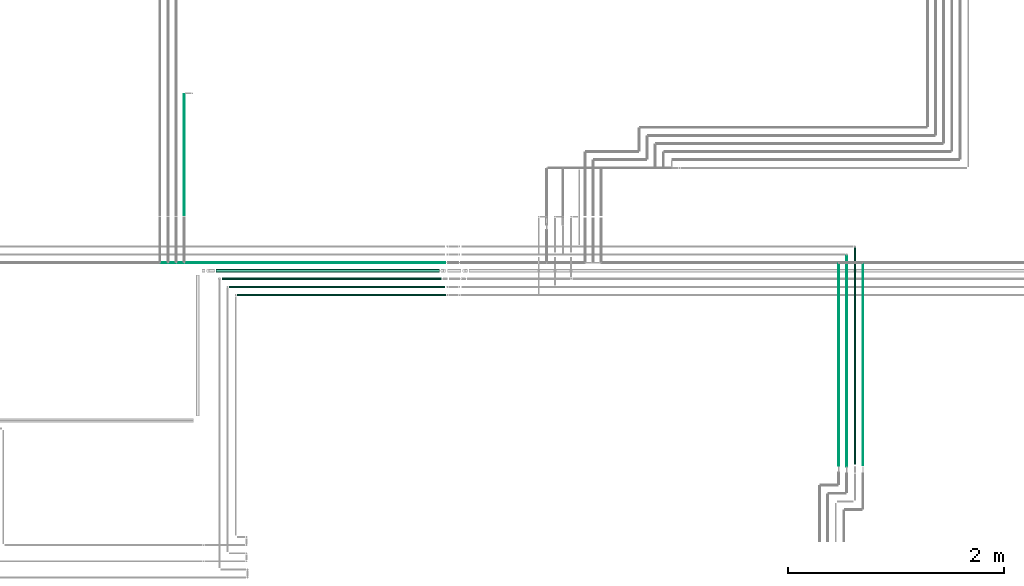
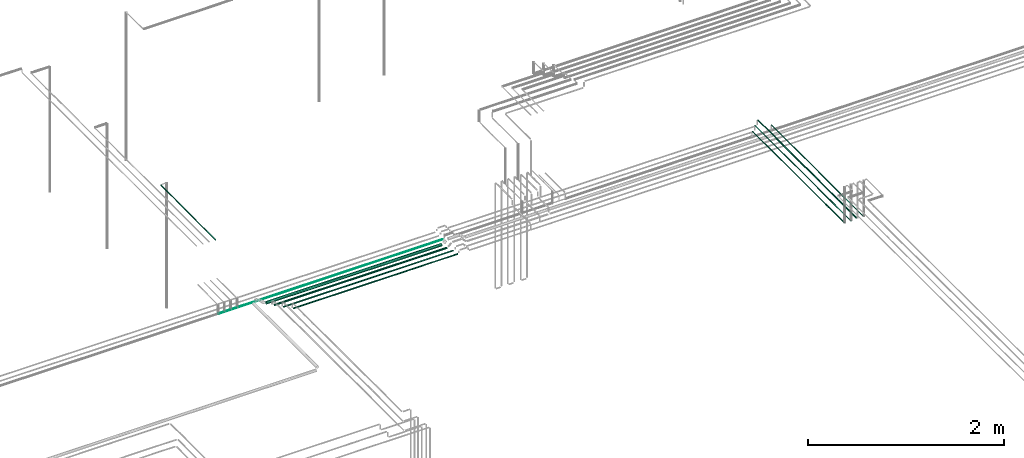
# One storey, part 25 of 331: 10 flow segments.
"""IFC2X3 building model written with IfcOpenShell, lengths in millimetres."""

from ifc_helpers import new_model, entity, si_unit, converted_unit, derived_unit, direction, frame, frame_2d, origin, origin_2d_with_axis, place, context, subcontext, project, spatial, circle, extrude, type_object, element, save


model = new_model("IFC2X3")

# Units and contexts
model_context = context("Model", 3, precision=0.01, world=origin(), true_north=direction((6.12303176911189e-17, 1.0)))
body_context = subcontext(model_context, "Body", "Model", "MODEL_VIEW")
ifc_project = project(units=[si_unit("LENGTHUNIT", "METRE", prefix="MILLI"), si_unit("AREAUNIT", "SQUARE_METRE"), si_unit("VOLUMEUNIT", "CUBIC_METRE"), converted_unit("PLANEANGLEUNIT", "DEGREE", entity("IfcRatioMeasure", 0.0174532925199433), si_unit("PLANEANGLEUNIT", "RADIAN"), dimensions=[0, 0, 0, 0, 0, 0, 0]), si_unit("MASSUNIT", "GRAM", prefix="KILO"), derived_unit("MASSDENSITYUNIT", [(si_unit("MASSUNIT", "GRAM", prefix="KILO"), 1), (si_unit("LENGTHUNIT", "METRE"), -3)]), derived_unit("MOMENTOFINERTIAUNIT", [(si_unit("LENGTHUNIT", "METRE"), 4)]), si_unit("TIMEUNIT", "SECOND"), si_unit("FREQUENCYUNIT", "HERTZ"), si_unit("THERMODYNAMICTEMPERATUREUNIT", "DEGREE_CELSIUS"), derived_unit("THERMALTRANSMITTANCEUNIT", [(si_unit("MASSUNIT", "GRAM", prefix="KILO"), 1), (si_unit("THERMODYNAMICTEMPERATUREUNIT", "KELVIN"), -1), (si_unit("TIMEUNIT", "SECOND"), -3)]), derived_unit("VOLUMETRICFLOWRATEUNIT", [(si_unit("LENGTHUNIT", "METRE"), 3), (si_unit("TIMEUNIT", "SECOND"), -1)]), derived_unit("MASSFLOWRATEUNIT", [(si_unit("MASSUNIT", "GRAM", prefix="KILO"), 1), (si_unit("TIMEUNIT", "SECOND"), -1)]), derived_unit("ROTATIONALFREQUENCYUNIT", [(si_unit("TIMEUNIT", "SECOND"), -1)]), si_unit("ELECTRICCURRENTUNIT", "AMPERE"), si_unit("ELECTRICVOLTAGEUNIT", "VOLT"), si_unit("POWERUNIT", "WATT"), si_unit("FORCEUNIT", "NEWTON", prefix="KILO"), si_unit("ILLUMINANCEUNIT", "LUX"), si_unit("LUMINOUSFLUXUNIT", "LUMEN"), si_unit("LUMINOUSINTENSITYUNIT", "CANDELA"), derived_unit("USERDEFINED", [(si_unit("MASSUNIT", "GRAM", prefix="KILO"), -1), (si_unit("LENGTHUNIT", "METRE"), -2), (si_unit("TIMEUNIT", "SECOND"), 3), (si_unit("LUMINOUSFLUXUNIT", "LUMEN"), 1)]), derived_unit("LINEARVELOCITYUNIT", [(si_unit("LENGTHUNIT", "METRE"), 1), (si_unit("TIMEUNIT", "SECOND"), -1)]), si_unit("PRESSUREUNIT", "PASCAL"), derived_unit("USERDEFINED", [(si_unit("LENGTHUNIT", "METRE"), -2), (si_unit("MASSUNIT", "GRAM", prefix="KILO"), 1), (si_unit("TIMEUNIT", "SECOND"), -2)]), derived_unit("LINEARFORCEUNIT", [(si_unit("MASSUNIT", "GRAM", prefix="KILO"), 1), (si_unit("LENGTHUNIT", "METRE"), 1), (si_unit("TIMEUNIT", "SECOND"), -2), (si_unit("LENGTHUNIT", "METRE"), -1)]), derived_unit("PLANARFORCEUNIT", [(si_unit("MASSUNIT", "GRAM", prefix="KILO"), 1), (si_unit("LENGTHUNIT", "METRE"), 1), (si_unit("TIMEUNIT", "SECOND"), -2), (si_unit("LENGTHUNIT", "METRE"), -2)])], contexts=[model_context])

# Site, building, storey
site_placement = place(None, frame((0.0, -0.00077364408347762, 0.0)))
site = spatial("IfcSite", under=ifc_project, at=site_placement, CompositionType="ELEMENT")
building_placement = place(site_placement, origin())
building = spatial("IfcBuilding", under=site, at=building_placement, CompositionType="ELEMENT")
storey_placement = place(building_placement, origin())
storey = spatial("IfcBuildingStorey", under=building, at=storey_placement, CompositionType="ELEMENT", Elevation=0.0)

# Flow segments
pipe_segment_type = type_object("IfcPipeSegmentType", PredefinedType="NOTDEFINED")
flow_segment_1_placement = place(building_placement, frame((34565.3073998838, 15805.889397967, 6655.90472776405)))
element("IfcFlowSegment", 1, at=flow_segment_1_placement, inside=storey, type_object=pipe_segment_type, context=body_context, shape_type="SweptSolid", body=[
    extrude(circle(Radius=17.5, at=frame_2d((2.16573425859679e-12, 0.0), x_axis=(1.0, 0.0))), frame((0.0, 19.0952722359184, 19.0952722359163), z_axis=(1.0, 0.0, 0.0), x_axis=(0.0, 1.0, 0.0)), (0.0, 0.0, 1.0), 2064.17813480539),
])
flow_segment_2_placement = place(building_placement, frame((40316.4101011924, 14020.0008331299, 6744.40472776409)))
element("IfcFlowSegment", 2, at=flow_segment_2_placement, inside=storey, type_object=pipe_segment_type, context=body_context, shape_type="SweptSolid", body=[
    extrude(circle(Radius=4.0, at=frame_2d((-8.66293703438714e-12, 0.0), x_axis=(1.0, 0.0))), frame((5.59527223591499, 0.0, 5.59527223591607), z_axis=(0.0, 1.0, 0.0), x_axis=(-1.0, 0.0, 0.0)), (0.0, 0.0, 1.0), 1869.98383707291),
])
flow_segment_3_placement = place(building_placement, frame((40391.4101011923, 14010.0008331299, 6744.40472776408)))
element("IfcFlowSegment", 3, at=flow_segment_3_placement, inside=storey, type_object=pipe_segment_type, context=body_context, shape_type="SweptSolid", body=[
    extrude(circle(Radius=4.0, at=frame_2d((0.0, 1.08286712929839e-12), x_axis=(1.0, 0.0))), frame((5.59527223591499, 0.0, 5.59527223591716), z_axis=(0.0, 1.0, 0.0), x_axis=(1.0, 0.0, 0.0)), (0.0, 0.0, 1.0), 1954.98383707304),
])
flow_segment_4_placement = place(building_placement, frame((40464.4101011923, 14033.0008331299, 6742.40472776409)))
element("IfcFlowSegment", 4, at=flow_segment_4_placement, inside=storey, type_object=pipe_segment_type, context=body_context, shape_type="SweptSolid", body=[
    extrude(circle(Radius=6.0, at=origin_2d_with_axis()), frame((7.59527223591454, 0.0, 7.59527223591562), z_axis=(0.0, 1.0, 0.0), x_axis=(-1.0, 0.0, 0.0)), (0.0, 0.0, 1.0), 2002.98383707304),
])
flow_segment_5_placement = place(building_placement, frame((40541.4101011924, 14027.0008331299, 6744.40472776409)))
element("IfcFlowSegment", 5, at=flow_segment_5_placement, inside=storey, type_object=pipe_segment_type, context=body_context, shape_type="SweptSolid", body=[
    extrude(circle(Radius=4.0, at=origin_2d_with_axis()), frame((5.59527223591499, 0.0, 5.59527223591607), z_axis=(0.0, 1.0, 0.0), x_axis=(-1.0, 0.0, 0.0)), (0.0, 0.0, 1.0), 1862.9838370729),
])
flow_segment_6_placement = place(storey_placement, frame((34264.8822000101, 16340.2501169888, 7244.33566793838)))
element("IfcFlowSegment", 6, at=flow_segment_6_placement, inside=storey, type_object=pipe_segment_type, context=body_context, shape_type="SweptSolid", body=[
    extrude(circle(Radius=4.0, at=origin_2d_with_axis()), frame((5.59527223591499, 0.000247807158046953, 5.59527222823855), z_axis=(0.0, 1.0, 6.19517897553015e-05), x_axis=(-1.0, 0.0, 0.0)), (0.0, 0.0, 1.0), 1114.73508122568),
])
flow_segment_7_placement = place(building_placement, frame((34758.9328642121, 15592.3893979671, 6667.40472776408)))
element("IfcFlowSegment", 7, at=flow_segment_7_placement, inside=storey, type_object=pipe_segment_type, context=body_context, shape_type="SweptSolid", body=[
    extrude(circle(Radius=6.0, at=frame_2d((0.0, -1.08286712929839e-12), x_axis=(1.0, 0.0))), frame((0.0, 7.5952722359297, 7.59527223591454), z_axis=(1.0, 0.0, 0.0), x_axis=(0.0, -1.0, 0.0)), (0.0, 0.0, 1.0), 1929.4765520313),
])
flow_segment_8_placement = place(building_placement, frame((34683.9328642122, 15667.389397967, 6667.40472776408)))
element("IfcFlowSegment", 8, at=flow_segment_8_placement, inside=storey, type_object=pipe_segment_type, context=body_context, shape_type="SweptSolid", body=[
    extrude(circle(Radius=6.0, at=frame_2d((0.0, -1.08286712929839e-12), x_axis=(1.0, 0.0))), frame((0.0, 7.59527223593186, 7.59527223591454), z_axis=(1.0, 0.0, 0.0), x_axis=(0.0, -1.0, 0.0)), (0.0, 0.0, 1.0), 1995.47655203129),
])
flow_segment_9_placement = place(building_placement, frame((34618.9328642122, 15737.389397967, 6662.40472776407)))
element("IfcFlowSegment", 9, at=flow_segment_9_placement, inside=storey, type_object=pipe_segment_type, context=body_context, shape_type="SweptSolid", body=[
    extrude(circle(Radius=11.0, at=frame_2d((-8.66293703438714e-12, 0.0), x_axis=(1.0, 0.0))), frame((0.0, 12.5952722359242, 12.5952722359156), z_axis=(1.0, 0.0, 0.0), x_axis=(0.0, 1.0, 0.0)), (0.0, 0.0, 1.0), 2029.48160266516),
])
flow_segment_10_placement = place(storey_placement, frame((34050.477472246, 15894.389397967, 6669.40472776409)))
element("IfcFlowSegment", 10, at=flow_segment_10_placement, inside=storey, type_object=pipe_segment_type, context=body_context, shape_type="SweptSolid", body=[
    extrude(circle(Radius=4.0, at=frame_2d((0.0, -1.08286712929839e-12), x_axis=(1.0, 0.0))), frame((0.0, 5.59527223592365, 5.59527223591499), z_axis=(1.0, 0.0, 0.0), x_axis=(0.0, -1.0, 0.0)), (0.0, 0.0, 1.0), 2634.93194399746),
])

save(model, "model.ifc")
